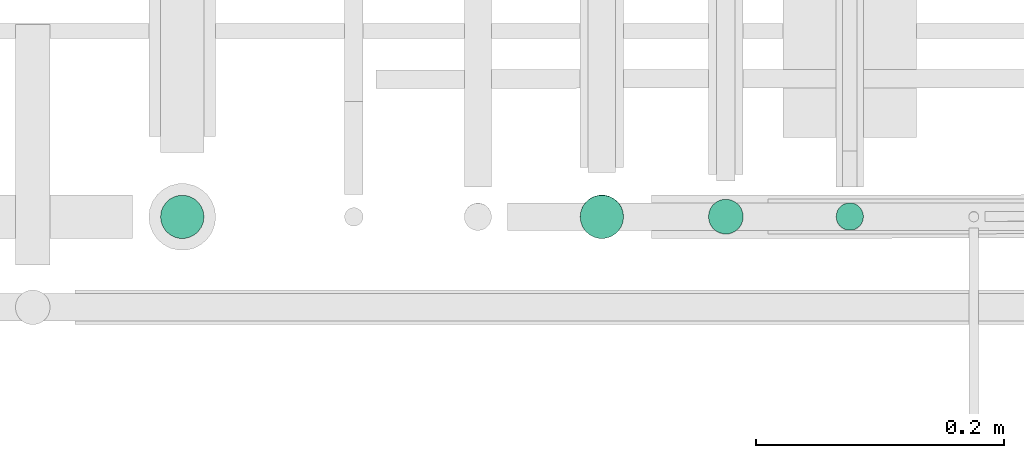
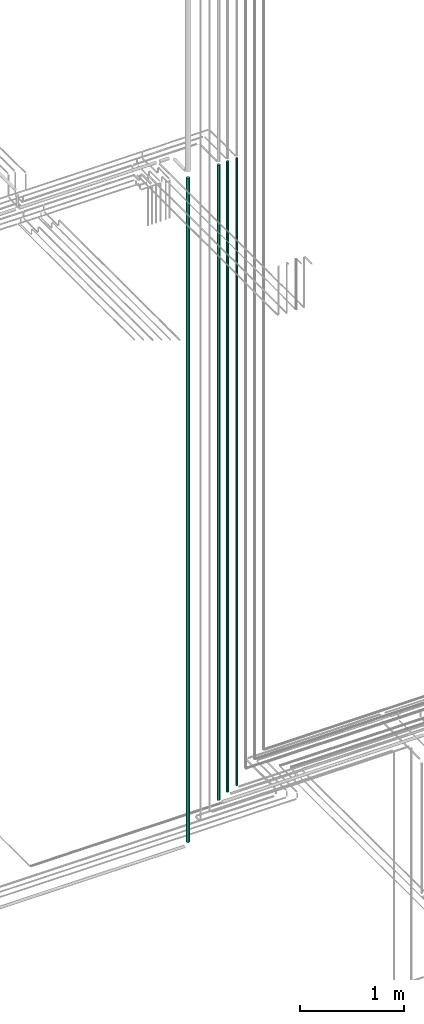
# One storey, part 82 of 331: 4 flow segments.
"""IFC2X3 building model written with IfcOpenShell, lengths in millimetres."""

from ifc_helpers import new_model, entity, si_unit, converted_unit, derived_unit, direction, frame, origin, origin_2d_with_axis, place, context, subcontext, project, spatial, circle, extrude, type_object, element, save


model = new_model("IFC2X3")

# Units and contexts
model_context = context("Model", 3, precision=0.01, world=origin(), true_north=direction((6.12303176911189e-17, 1.0)))
body_context = subcontext(model_context, "Body", "Model", "MODEL_VIEW")
ifc_project = project(units=[si_unit("LENGTHUNIT", "METRE", prefix="MILLI"), si_unit("AREAUNIT", "SQUARE_METRE"), si_unit("VOLUMEUNIT", "CUBIC_METRE"), converted_unit("PLANEANGLEUNIT", "DEGREE", entity("IfcRatioMeasure", 0.0174532925199433), si_unit("PLANEANGLEUNIT", "RADIAN"), dimensions=[0, 0, 0, 0, 0, 0, 0]), si_unit("MASSUNIT", "GRAM", prefix="KILO"), derived_unit("MASSDENSITYUNIT", [(si_unit("MASSUNIT", "GRAM", prefix="KILO"), 1), (si_unit("LENGTHUNIT", "METRE"), -3)]), derived_unit("MOMENTOFINERTIAUNIT", [(si_unit("LENGTHUNIT", "METRE"), 4)]), si_unit("TIMEUNIT", "SECOND"), si_unit("FREQUENCYUNIT", "HERTZ"), si_unit("THERMODYNAMICTEMPERATUREUNIT", "DEGREE_CELSIUS"), derived_unit("THERMALTRANSMITTANCEUNIT", [(si_unit("MASSUNIT", "GRAM", prefix="KILO"), 1), (si_unit("THERMODYNAMICTEMPERATUREUNIT", "KELVIN"), -1), (si_unit("TIMEUNIT", "SECOND"), -3)]), derived_unit("VOLUMETRICFLOWRATEUNIT", [(si_unit("LENGTHUNIT", "METRE"), 3), (si_unit("TIMEUNIT", "SECOND"), -1)]), derived_unit("MASSFLOWRATEUNIT", [(si_unit("MASSUNIT", "GRAM", prefix="KILO"), 1), (si_unit("TIMEUNIT", "SECOND"), -1)]), derived_unit("ROTATIONALFREQUENCYUNIT", [(si_unit("TIMEUNIT", "SECOND"), -1)]), si_unit("ELECTRICCURRENTUNIT", "AMPERE"), si_unit("ELECTRICVOLTAGEUNIT", "VOLT"), si_unit("POWERUNIT", "WATT"), si_unit("FORCEUNIT", "NEWTON", prefix="KILO"), si_unit("ILLUMINANCEUNIT", "LUX"), si_unit("LUMINOUSFLUXUNIT", "LUMEN"), si_unit("LUMINOUSINTENSITYUNIT", "CANDELA"), derived_unit("USERDEFINED", [(si_unit("MASSUNIT", "GRAM", prefix="KILO"), -1), (si_unit("LENGTHUNIT", "METRE"), -2), (si_unit("TIMEUNIT", "SECOND"), 3), (si_unit("LUMINOUSFLUXUNIT", "LUMEN"), 1)]), derived_unit("LINEARVELOCITYUNIT", [(si_unit("LENGTHUNIT", "METRE"), 1), (si_unit("TIMEUNIT", "SECOND"), -1)]), si_unit("PRESSUREUNIT", "PASCAL"), derived_unit("USERDEFINED", [(si_unit("LENGTHUNIT", "METRE"), -2), (si_unit("MASSUNIT", "GRAM", prefix="KILO"), 1), (si_unit("TIMEUNIT", "SECOND"), -2)]), derived_unit("LINEARFORCEUNIT", [(si_unit("MASSUNIT", "GRAM", prefix="KILO"), 1), (si_unit("LENGTHUNIT", "METRE"), 1), (si_unit("TIMEUNIT", "SECOND"), -2), (si_unit("LENGTHUNIT", "METRE"), -1)]), derived_unit("PLANARFORCEUNIT", [(si_unit("MASSUNIT", "GRAM", prefix="KILO"), 1), (si_unit("LENGTHUNIT", "METRE"), 1), (si_unit("TIMEUNIT", "SECOND"), -2), (si_unit("LENGTHUNIT", "METRE"), -2)])], contexts=[model_context])

# Site, building, storey
site_placement = place(None, frame((0.0, -0.00077364408347762, 0.0)))
site = spatial("IfcSite", under=ifc_project, at=site_placement, CompositionType="ELEMENT")
building_placement = place(site_placement, origin())
building = spatial("IfcBuilding", under=site, at=building_placement, CompositionType="ELEMENT")
storey_placement = place(building_placement, origin())
storey = spatial("IfcBuildingStorey", under=building, at=storey_placement, CompositionType="ELEMENT", Elevation=0.0)

# Flow segments
pipe_segment_type = type_object("IfcPipeSegmentType", PredefinedType="NOTDEFINED")
flow_segment_1_placement = place(building_placement, frame((64238.5166513322, 8135.58054612852, 7189.0)))
element("IfcFlowSegment", 1, at=flow_segment_1_placement, inside=storey, type_object=pipe_segment_type, context=body_context, shape_type="SweptSolid", body=[
    extrude(circle(Radius=11.0, at=origin_2d_with_axis()), frame((12.5952722359134, 12.5952722359156, 0.0), z_axis=(0.0, 0.0, 1.0), x_axis=(-1.0, 0.0, 0.0)), (0.0, 0.0, 1.0), 7349.00000002024),
])
flow_segment_2_placement = place(building_placement, frame((64135.5166110417, 8132.55584178518, 7149.0)))
element("IfcFlowSegment", 2, at=flow_segment_2_placement, inside=storey, type_object=pipe_segment_type, context=body_context, shape_type="SweptSolid", body=[
    extrude(circle(Radius=14.0, at=origin_2d_with_axis()), frame((15.5952722359127, 15.595272235916, 0.0), z_axis=(0.0, 0.0, 1.0), x_axis=(-1.0, 0.0, 0.0)), (0.0, 0.0, 1.0), 7386.00000001528),
])
flow_segment_3_placement = place(building_placement, frame((63693.5166110417, 8128.83499464522, 6715.0)))
element("IfcFlowSegment", 3, at=flow_segment_3_placement, inside=storey, type_object=pipe_segment_type, context=body_context, shape_type="SweptSolid", body=[
    extrude(circle(Radius=17.5, at=origin_2d_with_axis()), frame((19.0952722359119, 19.0952722359163, 0.0), z_axis=(0.0, 0.0, 1.0), x_axis=(-1.0, 0.0, 0.0)), (0.0, 0.0, 1.0), 7783.00000000002),
])
flow_segment_4_placement = place(building_placement, frame((64032.0166110417, 8128.83499464801, 7089.99968706555)))
element("IfcFlowSegment", 4, at=flow_segment_4_placement, inside=storey, type_object=pipe_segment_type, context=body_context, shape_type="SweptSolid", body=[
    extrude(circle(Radius=17.5, at=origin_2d_with_axis()), frame((19.0952722359119, 19.2282961882665, 0.000312934429967981), z_axis=(0.0, -1.78819673514032e-05, 1.0), x_axis=(-1.0, 0.0, 0.0)), (0.0, 0.0, 1.0), 7439.00000118939),
])

save(model, "model.ifc")
